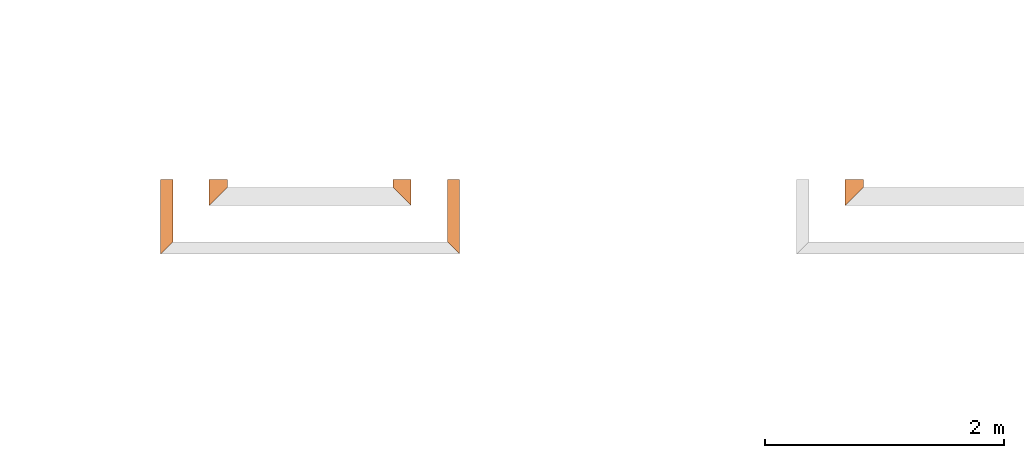
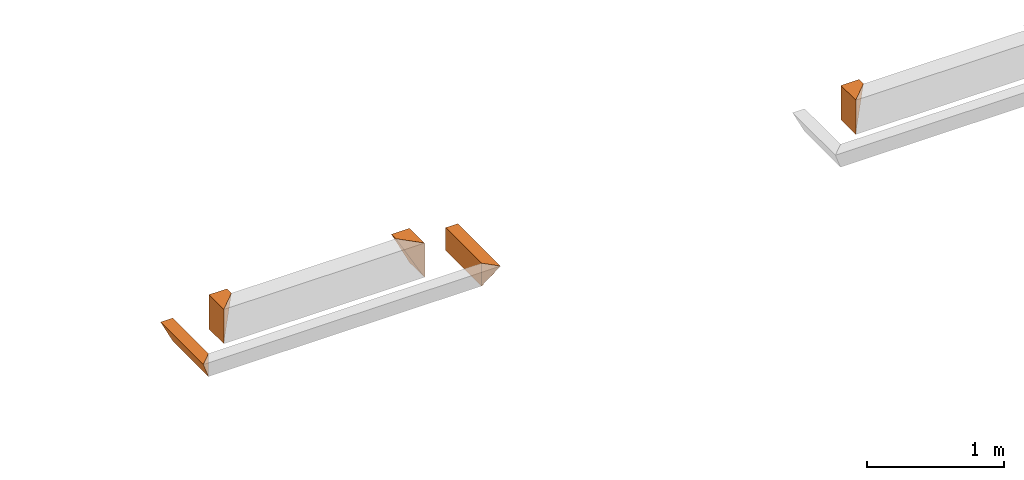
# One storey, part 5 of 8: 5 proxies.
"""IFC4 building model written with IfcOpenShell, lengths in feet."""

from ifc_helpers import new_model, entity, si_unit, converted_unit, derived_unit, direction, frame, origin, place, context, subcontext, project, spatial, type_object, element, save


model = new_model("IFC4")

# Units and contexts
model_context = context("Model", 3, precision=0.0001, world=origin(), true_north=direction((6.12303176911189e-17, 1.0)))
body_context = subcontext(model_context, "Body", "Model", "MODEL_VIEW")
ifc_project = project(units=[converted_unit("LENGTHUNIT", "FOOT", entity("IfcRatioMeasure", 0.3048), si_unit("LENGTHUNIT", "METRE"), dimensions=[1, 0, 0, 0, 0, 0, 0]), converted_unit("AREAUNIT", "SQUARE FOOT", entity("IfcRatioMeasure", 0.09290304), si_unit("AREAUNIT", "SQUARE_METRE"), dimensions=[2, 0, 0, 0, 0, 0, 0]), converted_unit("VOLUMEUNIT", "CUBIC FOOT", entity("IfcRatioMeasure", 0.028316846592), si_unit("VOLUMEUNIT", "CUBIC_METRE"), dimensions=[3, 0, 0, 0, 0, 0, 0]), converted_unit("PLANEANGLEUNIT", "DEGREE", entity("IfcRatioMeasure", 0.0174532925199433), si_unit("PLANEANGLEUNIT", "RADIAN"), dimensions=[0, 0, 0, 0, 0, 0, 0]), si_unit("MASSUNIT", "GRAM", prefix="KILO"), derived_unit("MASSDENSITYUNIT", [(si_unit("MASSUNIT", "GRAM", prefix="KILO"), 1), (si_unit("LENGTHUNIT", "METRE"), -3)]), derived_unit("MOMENTOFINERTIAUNIT", [(si_unit("LENGTHUNIT", "METRE"), 4)]), si_unit("TIMEUNIT", "SECOND"), si_unit("FREQUENCYUNIT", "HERTZ"), si_unit("THERMODYNAMICTEMPERATUREUNIT", "DEGREE_CELSIUS"), derived_unit("THERMALTRANSMITTANCEUNIT", [(si_unit("MASSUNIT", "GRAM", prefix="KILO"), 1), (si_unit("THERMODYNAMICTEMPERATUREUNIT", "KELVIN"), -1), (si_unit("TIMEUNIT", "SECOND"), -3)]), derived_unit("VOLUMETRICFLOWRATEUNIT", [(si_unit("LENGTHUNIT", "METRE"), 3), (si_unit("TIMEUNIT", "SECOND"), -1)]), si_unit("ELECTRICCURRENTUNIT", "AMPERE"), si_unit("ELECTRICVOLTAGEUNIT", "VOLT"), si_unit("POWERUNIT", "WATT"), si_unit("FORCEUNIT", "NEWTON"), si_unit("ILLUMINANCEUNIT", "LUX"), si_unit("LUMINOUSFLUXUNIT", "LUMEN"), si_unit("LUMINOUSINTENSITYUNIT", "CANDELA"), derived_unit("USERDEFINED", [(si_unit("MASSUNIT", "GRAM", prefix="KILO"), -1), (si_unit("LENGTHUNIT", "METRE"), -2), (si_unit("TIMEUNIT", "SECOND"), 3), (si_unit("LUMINOUSFLUXUNIT", "LUMEN"), 1)]), derived_unit("LINEARVELOCITYUNIT", [(si_unit("LENGTHUNIT", "METRE"), 1), (si_unit("TIMEUNIT", "SECOND"), -1)]), si_unit("PRESSUREUNIT", "PASCAL"), derived_unit("USERDEFINED", [(si_unit("LENGTHUNIT", "METRE"), -2), (si_unit("MASSUNIT", "GRAM", prefix="KILO"), 1), (si_unit("TIMEUNIT", "SECOND"), -2)]), derived_unit("LINEARFORCEUNIT", [(si_unit("MASSUNIT", "GRAM", prefix="KILO"), 1), (si_unit("LENGTHUNIT", "METRE"), 1), (si_unit("TIMEUNIT", "SECOND"), -2), (si_unit("LENGTHUNIT", "METRE"), -1)]), derived_unit("PLANARFORCEUNIT", [(si_unit("MASSUNIT", "GRAM", prefix="KILO"), 1), (si_unit("LENGTHUNIT", "METRE"), 1), (si_unit("TIMEUNIT", "SECOND"), -2), (si_unit("LENGTHUNIT", "METRE"), -2)])], contexts=[model_context])

# Site, building, storey
site_placement = place(None, origin())
site = spatial("IfcSite", under=ifc_project, at=site_placement, CompositionType="ELEMENT")
building_placement = place(site_placement, origin())
building = spatial("IfcBuilding", under=site, at=building_placement, CompositionType="ELEMENT")
storey_placement = place(building_placement, frame((0.0, 0.0, -12.6666666666667)))
storey = spatial("IfcBuildingStorey", under=building, at=storey_placement, Name="BASEMENT", CompositionType="ELEMENT", Elevation=-12.6666666666667)

# Proxies
building_element_proxy_type_1 = type_object("IfcBuildingElementProxyType", PredefinedType="NOTDEFINED")
proxy_1_placement = place(storey_placement, frame((-228.863157950076, 957.231726549317, 11.5833333333333)))
cartesian_point_1 = entity("IfcCartesianPoint", [0.5, 0.713552004822986, 0.0])
vertex_point_1 = entity("IfcVertexPoint", cartesian_point_1)
cartesian_point_2 = entity("IfcCartesianPoint", [0.0, 0.7135520048231, 1.0])
vertex_point_2 = entity("IfcVertexPoint", cartesian_point_2)
edge_curve_1 = entity("IfcEdgeCurve", vertex_point_1, vertex_point_2, entity("IfcTrimmedCurve", entity("IfcLine", cartesian_point_1, entity("IfcVector", entity("IfcDirection", [-0.44721359549996, 0.0, 0.894427190999915]), 1.0)), [cartesian_point_1], [cartesian_point_2], True, "CARTESIAN"), True)
cartesian_point_3 = entity("IfcCartesianPoint", [0.5, 0.713552004822986, 1.0])
vertex_point_3 = entity("IfcVertexPoint", cartesian_point_3)
ifc_direction_1 = entity("IfcDirection", [1.0, 0.0, 0.0])
edge_curve_2 = entity("IfcEdgeCurve", vertex_point_2, vertex_point_3, entity("IfcTrimmedCurve", entity("IfcLine", cartesian_point_2, entity("IfcVector", ifc_direction_1, 1.0)), [cartesian_point_2], [cartesian_point_3], True, "CARTESIAN"), True)
cartesian_point_4 = entity("IfcCartesianPoint", [0.5, 0.713552004822986, 0.669270833333341])
vertex_point_4 = entity("IfcVertexPoint", cartesian_point_4)
ifc_direction_2 = entity("IfcDirection", [0.0, 0.0, -1.0])
edge_curve_3 = entity("IfcEdgeCurve", vertex_point_3, vertex_point_4, entity("IfcTrimmedCurve", entity("IfcLine", cartesian_point_3, entity("IfcVector", ifc_direction_2, 1.0)), [cartesian_point_3], [cartesian_point_4], True, "CARTESIAN"), True)
edge_curve_4 = entity("IfcEdgeCurve", vertex_point_4, vertex_point_1, entity("IfcTrimmedCurve", entity("IfcLine", cartesian_point_4, entity("IfcVector", ifc_direction_2, 1.0)), [cartesian_point_4], [cartesian_point_1], True, "CARTESIAN"), True)
ifc_direction_3 = entity("IfcDirection", [0.0, 1.0, 0.0])
cartesian_point_5 = entity("IfcCartesianPoint", [0.0, 0.5, 1.0])
vertex_point_5 = entity("IfcVertexPoint", cartesian_point_5)
cartesian_point_6 = entity("IfcCartesianPoint", [0.499999999999972, 0.0, 0.0])
vertex_point_6 = entity("IfcVertexPoint", cartesian_point_6)
edge_curve_5 = entity("IfcEdgeCurve", vertex_point_5, vertex_point_6, entity("IfcTrimmedCurve", entity("IfcLine", cartesian_point_5, entity("IfcVector", entity("IfcDirection", [0.408248290463845, -0.408248290463868, -0.816496580927733]), 1.0)), [cartesian_point_5], [cartesian_point_6], True, "CARTESIAN"), True)
cartesian_point_7 = entity("IfcCartesianPoint", [0.499999999999972, 0.0, 0.669270833333341])
vertex_point_7 = entity("IfcVertexPoint", cartesian_point_7)
ifc_direction_4 = entity("IfcDirection", [0.0, 0.0, 1.0])
edge_curve_6 = entity("IfcEdgeCurve", vertex_point_6, vertex_point_7, entity("IfcTrimmedCurve", entity("IfcLine", cartesian_point_6, entity("IfcVector", ifc_direction_4, 1.0)), [cartesian_point_6], [cartesian_point_7], True, "CARTESIAN"), True)
cartesian_point_8 = entity("IfcCartesianPoint", [0.499999999999972, 0.0, 1.0])
vertex_point_8 = entity("IfcVertexPoint", cartesian_point_8)
edge_curve_7 = entity("IfcEdgeCurve", vertex_point_7, vertex_point_8, entity("IfcTrimmedCurve", entity("IfcLine", cartesian_point_7, entity("IfcVector", ifc_direction_4, 1.0)), [cartesian_point_7], [cartesian_point_8], True, "CARTESIAN"), True)
edge_curve_8 = entity("IfcEdgeCurve", vertex_point_8, vertex_point_5, entity("IfcTrimmedCurve", entity("IfcLine", cartesian_point_8, entity("IfcVector", entity("IfcDirection", [-0.707106781186527, 0.707106781186568, 0.0]), 1.0)), [cartesian_point_8], [cartesian_point_5], True, "CARTESIAN"), True)
ifc_direction_5 = entity("IfcDirection", [0.0, -1.0, 0.0])
edge_curve_9 = entity("IfcEdgeCurve", vertex_point_1, vertex_point_6, entity("IfcTrimmedCurve", entity("IfcLine", cartesian_point_1, entity("IfcVector", ifc_direction_5, 1.0)), [cartesian_point_1], [cartesian_point_6], True, "CARTESIAN"), True)
edge_curve_10 = entity("IfcEdgeCurve", vertex_point_5, vertex_point_2, entity("IfcTrimmedCurve", entity("IfcLine", cartesian_point_2, entity("IfcVector", ifc_direction_3, 1.0)), [cartesian_point_5], [cartesian_point_2], True, "CARTESIAN"), True)
edge_curve_11 = entity("IfcEdgeCurve", vertex_point_8, vertex_point_3, entity("IfcTrimmedCurve", entity("IfcLine", cartesian_point_3, entity("IfcVector", ifc_direction_3, 1.0)), [cartesian_point_8], [cartesian_point_3], True, "CARTESIAN"), True)
element("IfcBuildingElementProxy", 1, at=proxy_1_placement, inside=storey, type_object=building_element_proxy_type_1, PredefinedType="NOTDEFINED", context=body_context, shape_type="AdvancedBrep", body=[
    entity("IfcAdvancedBrep", entity("IfcClosedShell", [entity("IfcAdvancedFace", [entity("IfcFaceOuterBound", entity("IfcEdgeLoop", [entity("IfcOrientedEdge", None, None, edge_curve_1, True), entity("IfcOrientedEdge", None, None, edge_curve_2, True), entity("IfcOrientedEdge", None, None, edge_curve_3, True), entity("IfcOrientedEdge", None, None, edge_curve_4, True)]), True)], entity("IfcPlane", entity("IfcAxis2Placement3D", entity("IfcCartesianPoint", [-0.5, 0.7135520048231, 1.0]), ifc_direction_3, ifc_direction_2)), True), entity("IfcAdvancedFace", [entity("IfcFaceOuterBound", entity("IfcEdgeLoop", [entity("IfcOrientedEdge", None, None, edge_curve_5, True), entity("IfcOrientedEdge", None, None, edge_curve_6, True), entity("IfcOrientedEdge", None, None, edge_curve_7, True), entity("IfcOrientedEdge", None, None, edge_curve_8, True)]), True)], entity("IfcPlane", entity("IfcAxis2Placement3D", entity("IfcCartesianPoint", [0.499999999999972, 0.0, 2.0]), entity("IfcDirection", [-0.707106781186562, -0.707106781186533, 0.0]), entity("IfcDirection", [-0.707106781186533, 0.707106781186562, 0.0]))), True), entity("IfcAdvancedFace", [entity("IfcFaceOuterBound", entity("IfcEdgeLoop", [entity("IfcOrientedEdge", None, None, edge_curve_1, False), entity("IfcOrientedEdge", None, None, edge_curve_9, True), entity("IfcOrientedEdge", None, None, edge_curve_5, False), entity("IfcOrientedEdge", None, None, edge_curve_10, True)]), True)], entity("IfcPlane", entity("IfcAxis2Placement3D", cartesian_point_1, entity("IfcDirection", [-0.894427190999915, 0.0, -0.447213595499961]), ifc_direction_5)), True), entity("IfcAdvancedFace", [entity("IfcFaceOuterBound", entity("IfcEdgeLoop", [entity("IfcOrientedEdge", None, None, edge_curve_2, False), entity("IfcOrientedEdge", None, None, edge_curve_10, False), entity("IfcOrientedEdge", None, None, edge_curve_8, False), entity("IfcOrientedEdge", None, None, edge_curve_11, True)]), True)], entity("IfcPlane", entity("IfcAxis2Placement3D", cartesian_point_2, ifc_direction_4, ifc_direction_5)), True), entity("IfcAdvancedFace", [entity("IfcFaceOuterBound", entity("IfcEdgeLoop", [entity("IfcOrientedEdge", None, None, edge_curve_11, False), entity("IfcOrientedEdge", None, None, edge_curve_7, False), entity("IfcOrientedEdge", None, None, edge_curve_6, False), entity("IfcOrientedEdge", None, None, edge_curve_9, False), entity("IfcOrientedEdge", None, None, edge_curve_4, False), entity("IfcOrientedEdge", None, None, edge_curve_3, False)]), True)], entity("IfcPlane", entity("IfcAxis2Placement3D", cartesian_point_3, ifc_direction_1, ifc_direction_5)), True)])),
])
building_element_proxy_type_2 = type_object("IfcBuildingElementProxyType", PredefinedType="NOTDEFINED")
proxy_2_placement = place(storey_placement, frame((-227.363157950076, 955.89709113265, 11.5833333333333)))
cartesian_point_9 = entity("IfcCartesianPoint", [0.0, 2.04818742148973, 0.0])
vertex_point_9 = entity("IfcVertexPoint", cartesian_point_9)
cartesian_point_10 = entity("IfcCartesianPoint", [0.0, 2.04818742148973, 0.669270833333343])
vertex_point_10 = entity("IfcVertexPoint", cartesian_point_10)
ifc_direction_6 = entity("IfcDirection", [0.0, 0.0, 1.0])
edge_curve_12 = entity("IfcEdgeCurve", vertex_point_9, vertex_point_10, entity("IfcTrimmedCurve", entity("IfcLine", cartesian_point_9, entity("IfcVector", ifc_direction_6, 1.0)), [cartesian_point_9], [cartesian_point_10], True, "CARTESIAN"), True)
cartesian_point_11 = entity("IfcCartesianPoint", [0.334635416666885, 2.04818742148962, 0.669270833333343])
vertex_point_11 = entity("IfcVertexPoint", cartesian_point_11)
ifc_direction_7 = entity("IfcDirection", [1.0, 0.0, 0.0])
edge_curve_13 = entity("IfcEdgeCurve", vertex_point_10, vertex_point_11, entity("IfcTrimmedCurve", entity("IfcLine", cartesian_point_10, entity("IfcVector", ifc_direction_7, 1.0)), [cartesian_point_10], [cartesian_point_11], True, "CARTESIAN"), True)
edge_curve_14 = entity("IfcEdgeCurve", vertex_point_11, vertex_point_9, entity("IfcTrimmedCurve", entity("IfcLine", cartesian_point_11, entity("IfcVector", entity("IfcDirection", [-0.447213595499947, 0.0, -0.894427190999921]), 1.0)), [cartesian_point_11], [cartesian_point_9], True, "CARTESIAN"), True)
ifc_direction_8 = entity("IfcDirection", [0.0, 1.0, 0.0])
ifc_direction_9 = entity("IfcDirection", [0.0, 0.0, -1.0])
cartesian_point_12 = entity("IfcCartesianPoint", [0.0, 0.334635416666742, 0.0])
vertex_point_12 = entity("IfcVertexPoint", cartesian_point_12)
cartesian_point_13 = entity("IfcCartesianPoint", [0.334635416666828, 0.0, 0.669270833333343])
vertex_point_13 = entity("IfcVertexPoint", cartesian_point_13)
edge_curve_15 = entity("IfcEdgeCurve", vertex_point_12, vertex_point_13, entity("IfcTrimmedCurve", entity("IfcLine", cartesian_point_12, entity("IfcVector", entity("IfcDirection", [0.40824829046386, -0.408248290463825, 0.816496580927747]), 1.0)), [cartesian_point_12], [cartesian_point_13], True, "CARTESIAN"), True)
cartesian_point_14 = entity("IfcCartesianPoint", [0.0, 0.33463541666697, 0.669270833333343])
vertex_point_14 = entity("IfcVertexPoint", cartesian_point_14)
edge_curve_16 = entity("IfcEdgeCurve", vertex_point_13, vertex_point_14, entity("IfcTrimmedCurve", entity("IfcLine", cartesian_point_13, entity("IfcVector", entity("IfcDirection", [-0.707106781186517, 0.707106781186578, 0.0]), 1.0)), [cartesian_point_13], [cartesian_point_14], True, "CARTESIAN"), True)
edge_curve_17 = entity("IfcEdgeCurve", vertex_point_14, vertex_point_12, entity("IfcTrimmedCurve", entity("IfcLine", cartesian_point_14, entity("IfcVector", ifc_direction_9, 1.0)), [cartesian_point_14], [cartesian_point_12], True, "CARTESIAN"), True)
ifc_direction_10 = entity("IfcDirection", [0.0, -1.0, 0.0])
edge_curve_18 = entity("IfcEdgeCurve", vertex_point_9, vertex_point_12, entity("IfcTrimmedCurve", entity("IfcLine", cartesian_point_9, entity("IfcVector", ifc_direction_10, 1.0)), [cartesian_point_9], [cartesian_point_12], True, "CARTESIAN"), True)
edge_curve_19 = entity("IfcEdgeCurve", vertex_point_14, vertex_point_10, entity("IfcTrimmedCurve", entity("IfcLine", cartesian_point_14, entity("IfcVector", ifc_direction_8, 1.0)), [cartesian_point_14], [cartesian_point_10], True, "CARTESIAN"), True)
edge_curve_20 = entity("IfcEdgeCurve", vertex_point_11, vertex_point_13, entity("IfcTrimmedCurve", entity("IfcLine", cartesian_point_11, entity("IfcVector", ifc_direction_10, 1.0)), [cartesian_point_11], [cartesian_point_13], True, "CARTESIAN"), True)
element("IfcBuildingElementProxy", 2, at=proxy_2_placement, inside=storey, type_object=building_element_proxy_type_2, PredefinedType="NOTDEFINED", context=body_context, shape_type="AdvancedBrep", body=[
    entity("IfcAdvancedBrep", entity("IfcClosedShell", [entity("IfcAdvancedFace", [entity("IfcFaceOuterBound", entity("IfcEdgeLoop", [entity("IfcOrientedEdge", None, None, edge_curve_12, True), entity("IfcOrientedEdge", None, None, edge_curve_13, True), entity("IfcOrientedEdge", None, None, edge_curve_14, True)]), True)], entity("IfcPlane", entity("IfcAxis2Placement3D", entity("IfcCartesianPoint", [-1.0, 2.04818742148973, 1.0]), ifc_direction_8, ifc_direction_9)), True), entity("IfcAdvancedFace", [entity("IfcFaceOuterBound", entity("IfcEdgeLoop", [entity("IfcOrientedEdge", None, None, edge_curve_15, True), entity("IfcOrientedEdge", None, None, edge_curve_16, True), entity("IfcOrientedEdge", None, None, edge_curve_17, True)]), True)], entity("IfcPlane", entity("IfcAxis2Placement3D", entity("IfcCartesianPoint", [0.0, 0.334635416666742, 2.0]), entity("IfcDirection", [-0.707106781186562, -0.707106781186533, 0.0]), entity("IfcDirection", [-0.707106781186533, 0.707106781186562, 0.0]))), True), entity("IfcAdvancedFace", [entity("IfcFaceOuterBound", entity("IfcEdgeLoop", [entity("IfcOrientedEdge", None, None, edge_curve_18, True), entity("IfcOrientedEdge", None, None, edge_curve_17, False), entity("IfcOrientedEdge", None, None, edge_curve_19, True), entity("IfcOrientedEdge", None, None, edge_curve_12, False)]), True)], entity("IfcPlane", entity("IfcAxis2Placement3D", cartesian_point_9, entity("IfcDirection", [-1.0, 0.0, 0.0]), ifc_direction_10)), True), entity("IfcAdvancedFace", [entity("IfcFaceOuterBound", entity("IfcEdgeLoop", [entity("IfcOrientedEdge", None, None, edge_curve_18, False), entity("IfcOrientedEdge", None, None, edge_curve_14, False), entity("IfcOrientedEdge", None, None, edge_curve_20, True), entity("IfcOrientedEdge", None, None, edge_curve_15, False)]), True)], entity("IfcPlane", entity("IfcAxis2Placement3D", entity("IfcCartesianPoint", [0.500000000000227, 2.04818742148962, 1.0]), entity("IfcDirection", [0.894427190999915, 0.0, -0.447213595499961]), ifc_direction_10)), True), entity("IfcAdvancedFace", [entity("IfcFaceOuterBound", entity("IfcEdgeLoop", [entity("IfcOrientedEdge", None, None, edge_curve_13, False), entity("IfcOrientedEdge", None, None, edge_curve_19, False), entity("IfcOrientedEdge", None, None, edge_curve_16, False), entity("IfcOrientedEdge", None, None, edge_curve_20, False)]), True)], entity("IfcPlane", entity("IfcAxis2Placement3D", entity("IfcCartesianPoint", [85.6250051391024, 2.96484375000068, 0.669270833333343]), ifc_direction_6, ifc_direction_7)), True)])),
])
building_element_proxy_type_3 = type_object("IfcBuildingElementProxyType", PredefinedType="NOTDEFINED")
proxy_3_placement = place(storey_placement, frame((-233.904827319654, 957.231726549317, 11.5833333333333)))
cartesian_point_15 = entity("IfcCartesianPoint", [0.5, 0.7135520048231, 1.0])
vertex_point_15 = entity("IfcVertexPoint", cartesian_point_15)
cartesian_point_16 = entity("IfcCartesianPoint", [0.0, 0.713552004822986, 0.0])
vertex_point_16 = entity("IfcVertexPoint", cartesian_point_16)
edge_curve_21 = entity("IfcEdgeCurve", vertex_point_15, vertex_point_16, entity("IfcTrimmedCurve", entity("IfcLine", cartesian_point_15, entity("IfcVector", entity("IfcDirection", [-0.44721359549996, 0.0, -0.894427190999915]), 1.0)), [cartesian_point_15], [cartesian_point_16], True, "CARTESIAN"), True)
cartesian_point_17 = entity("IfcCartesianPoint", [0.0, 0.713552004822986, 0.669270833333341])
vertex_point_17 = entity("IfcVertexPoint", cartesian_point_17)
ifc_direction_11 = entity("IfcDirection", [0.0, 0.0, 1.0])
edge_curve_22 = entity("IfcEdgeCurve", vertex_point_16, vertex_point_17, entity("IfcTrimmedCurve", entity("IfcLine", cartesian_point_16, entity("IfcVector", ifc_direction_11, 1.0)), [cartesian_point_16], [cartesian_point_17], True, "CARTESIAN"), True)
cartesian_point_18 = entity("IfcCartesianPoint", [0.0, 0.713552004822986, 1.0])
vertex_point_18 = entity("IfcVertexPoint", cartesian_point_18)
edge_curve_23 = entity("IfcEdgeCurve", vertex_point_17, vertex_point_18, entity("IfcTrimmedCurve", entity("IfcLine", cartesian_point_17, entity("IfcVector", ifc_direction_11, 1.0)), [cartesian_point_17], [cartesian_point_18], True, "CARTESIAN"), True)
edge_curve_24 = entity("IfcEdgeCurve", vertex_point_18, vertex_point_15, entity("IfcTrimmedCurve", entity("IfcLine", cartesian_point_18, entity("IfcVector", entity("IfcDirection", [1.0, 0.0, 0.0]), 1.0)), [cartesian_point_18], [cartesian_point_15], True, "CARTESIAN"), True)
ifc_direction_12 = entity("IfcDirection", [0.0, 1.0, 0.0])
ifc_direction_13 = entity("IfcDirection", [0.0, 0.0, -1.0])
cartesian_point_19 = entity("IfcCartesianPoint", [0.0, 0.0, 0.0])
vertex_point_19 = entity("IfcVertexPoint", cartesian_point_19)
cartesian_point_20 = entity("IfcCartesianPoint", [0.500000000000028, 0.5, 1.0])
vertex_point_20 = entity("IfcVertexPoint", cartesian_point_20)
edge_curve_25 = entity("IfcEdgeCurve", vertex_point_19, vertex_point_20, entity("IfcTrimmedCurve", entity("IfcLine", cartesian_point_19, entity("IfcVector", entity("IfcDirection", [0.408248290463864, 0.408248290463864, 0.816496580927725]), 1.0)), [cartesian_point_19], [cartesian_point_20], True, "CARTESIAN"), True)
cartesian_point_21 = entity("IfcCartesianPoint", [0.0, 0.0, 1.0])
vertex_point_21 = entity("IfcVertexPoint", cartesian_point_21)
edge_curve_26 = entity("IfcEdgeCurve", vertex_point_20, vertex_point_21, entity("IfcTrimmedCurve", entity("IfcLine", cartesian_point_20, entity("IfcVector", entity("IfcDirection", [-0.707106781186547, -0.707106781186547, 0.0]), 1.0)), [cartesian_point_20], [cartesian_point_21], True, "CARTESIAN"), True)
cartesian_point_22 = entity("IfcCartesianPoint", [0.0, 0.0, 0.669270833333341])
vertex_point_22 = entity("IfcVertexPoint", cartesian_point_22)
edge_curve_27 = entity("IfcEdgeCurve", vertex_point_21, vertex_point_22, entity("IfcTrimmedCurve", entity("IfcLine", cartesian_point_21, entity("IfcVector", ifc_direction_13, 1.0)), [cartesian_point_21], [cartesian_point_22], True, "CARTESIAN"), True)
edge_curve_28 = entity("IfcEdgeCurve", vertex_point_22, vertex_point_19, entity("IfcTrimmedCurve", entity("IfcLine", cartesian_point_22, entity("IfcVector", ifc_direction_13, 1.0)), [cartesian_point_22], [cartesian_point_19], True, "CARTESIAN"), True)
ifc_direction_14 = entity("IfcDirection", [0.0, -1.0, 0.0])
edge_curve_29 = entity("IfcEdgeCurve", vertex_point_15, vertex_point_20, entity("IfcTrimmedCurve", entity("IfcLine", cartesian_point_15, entity("IfcVector", ifc_direction_14, 1.0)), [cartesian_point_15], [cartesian_point_20], True, "CARTESIAN"), True)
edge_curve_30 = entity("IfcEdgeCurve", vertex_point_19, vertex_point_16, entity("IfcTrimmedCurve", entity("IfcLine", cartesian_point_16, entity("IfcVector", ifc_direction_12, 1.0)), [cartesian_point_19], [cartesian_point_16], True, "CARTESIAN"), True)
edge_curve_31 = entity("IfcEdgeCurve", vertex_point_18, vertex_point_21, entity("IfcTrimmedCurve", entity("IfcLine", cartesian_point_18, entity("IfcVector", ifc_direction_14, 1.0)), [cartesian_point_18], [cartesian_point_21], True, "CARTESIAN"), True)
element("IfcBuildingElementProxy", 3, at=proxy_3_placement, inside=storey, type_object=building_element_proxy_type_3, PredefinedType="NOTDEFINED", context=body_context, shape_type="AdvancedBrep", body=[
    entity("IfcAdvancedBrep", entity("IfcClosedShell", [entity("IfcAdvancedFace", [entity("IfcFaceOuterBound", entity("IfcEdgeLoop", [entity("IfcOrientedEdge", None, None, edge_curve_21, True), entity("IfcOrientedEdge", None, None, edge_curve_22, True), entity("IfcOrientedEdge", None, None, edge_curve_23, True), entity("IfcOrientedEdge", None, None, edge_curve_24, True)]), True)], entity("IfcPlane", entity("IfcAxis2Placement3D", entity("IfcCartesianPoint", [-1.0, 0.713552004822986, 1.0]), ifc_direction_12, ifc_direction_13)), True), entity("IfcAdvancedFace", [entity("IfcFaceOuterBound", entity("IfcEdgeLoop", [entity("IfcOrientedEdge", None, None, edge_curve_25, True), entity("IfcOrientedEdge", None, None, edge_curve_26, True), entity("IfcOrientedEdge", None, None, edge_curve_27, True), entity("IfcOrientedEdge", None, None, edge_curve_28, True)]), True)], entity("IfcPlane", entity("IfcAxis2Placement3D", cartesian_point_19, entity("IfcDirection", [0.707106781186548, -0.707106781186548, 0.0]), entity("IfcDirection", [0.707106781186548, 0.707106781186548, 0.0]))), True), entity("IfcAdvancedFace", [entity("IfcFaceOuterBound", entity("IfcEdgeLoop", [entity("IfcOrientedEdge", None, None, edge_curve_21, False), entity("IfcOrientedEdge", None, None, edge_curve_29, True), entity("IfcOrientedEdge", None, None, edge_curve_25, False), entity("IfcOrientedEdge", None, None, edge_curve_30, True)]), True)], entity("IfcPlane", entity("IfcAxis2Placement3D", cartesian_point_15, entity("IfcDirection", [0.894427190999915, 0.0, -0.447213595499961]), ifc_direction_14)), True), entity("IfcAdvancedFace", [entity("IfcFaceOuterBound", entity("IfcEdgeLoop", [entity("IfcOrientedEdge", None, None, edge_curve_24, False), entity("IfcOrientedEdge", None, None, edge_curve_31, True), entity("IfcOrientedEdge", None, None, edge_curve_26, False), entity("IfcOrientedEdge", None, None, edge_curve_29, False)]), True)], entity("IfcPlane", entity("IfcAxis2Placement3D", cartesian_point_18, ifc_direction_11, ifc_direction_14)), True), entity("IfcAdvancedFace", [entity("IfcFaceOuterBound", entity("IfcEdgeLoop", [entity("IfcOrientedEdge", None, None, edge_curve_31, False), entity("IfcOrientedEdge", None, None, edge_curve_23, False), entity("IfcOrientedEdge", None, None, edge_curve_22, False), entity("IfcOrientedEdge", None, None, edge_curve_30, False), entity("IfcOrientedEdge", None, None, edge_curve_28, False), entity("IfcOrientedEdge", None, None, edge_curve_27, False)]), True)], entity("IfcPlane", entity("IfcAxis2Placement3D", cartesian_point_16, entity("IfcDirection", [-1.0, 0.0, 0.0]), ifc_direction_14)), True)])),
])
building_element_proxy_type_4 = type_object("IfcBuildingElementProxyType", PredefinedType="NOTDEFINED")
proxy_4_placement = place(storey_placement, frame((-235.239462736321, 955.89709113265, 11.5833333333333)))
cartesian_point_23 = entity("IfcCartesianPoint", [0.334635416666686, 2.04818742148973, 0.0])
vertex_point_23 = entity("IfcVertexPoint", cartesian_point_23)
cartesian_point_24 = entity("IfcCartesianPoint", [0.0, 2.04818742148973, 0.669270833333343])
vertex_point_24 = entity("IfcVertexPoint", cartesian_point_24)
edge_curve_32 = entity("IfcEdgeCurve", vertex_point_23, vertex_point_24, entity("IfcTrimmedCurve", entity("IfcLine", cartesian_point_23, entity("IfcVector", entity("IfcDirection", [-0.447213595499947, 0.0, 0.894427190999921]), 1.0)), [cartesian_point_23], [cartesian_point_24], True, "CARTESIAN"), True)
cartesian_point_25 = entity("IfcCartesianPoint", [0.334635416666686, 2.04818742148973, 0.669270833333343])
vertex_point_25 = entity("IfcVertexPoint", cartesian_point_25)
ifc_direction_15 = entity("IfcDirection", [1.0, 0.0, 0.0])
edge_curve_33 = entity("IfcEdgeCurve", vertex_point_24, vertex_point_25, entity("IfcTrimmedCurve", entity("IfcLine", cartesian_point_24, entity("IfcVector", ifc_direction_15, 1.0)), [cartesian_point_24], [cartesian_point_25], True, "CARTESIAN"), True)
ifc_direction_16 = entity("IfcDirection", [0.0, 0.0, -1.0])
edge_curve_34 = entity("IfcEdgeCurve", vertex_point_25, vertex_point_23, entity("IfcTrimmedCurve", entity("IfcLine", cartesian_point_25, entity("IfcVector", ifc_direction_16, 1.0)), [cartesian_point_25], [cartesian_point_23], True, "CARTESIAN"), True)
ifc_direction_17 = entity("IfcDirection", [0.0, 1.0, 0.0])
cartesian_point_26 = entity("IfcCartesianPoint", [0.334635416666742, 0.334635416666742, 0.0])
vertex_point_26 = entity("IfcVertexPoint", cartesian_point_26)
cartesian_point_27 = entity("IfcCartesianPoint", [0.334635416666742, 0.334635416666742, 0.669270833333343])
vertex_point_27 = entity("IfcVertexPoint", cartesian_point_27)
ifc_direction_18 = entity("IfcDirection", [0.0, 0.0, 1.0])
edge_curve_35 = entity("IfcEdgeCurve", vertex_point_26, vertex_point_27, entity("IfcTrimmedCurve", entity("IfcLine", cartesian_point_26, entity("IfcVector", ifc_direction_18, 1.0)), [cartesian_point_26], [cartesian_point_27], True, "CARTESIAN"), True)
cartesian_point_28 = entity("IfcCartesianPoint", [0.0, 0.0, 0.669270833333343])
vertex_point_28 = entity("IfcVertexPoint", cartesian_point_28)
edge_curve_36 = entity("IfcEdgeCurve", vertex_point_27, vertex_point_28, entity("IfcTrimmedCurve", entity("IfcLine", cartesian_point_27, entity("IfcVector", entity("IfcDirection", [-0.707106781186578, -0.707106781186517, 0.0]), 1.0)), [cartesian_point_27], [cartesian_point_28], True, "CARTESIAN"), True)
edge_curve_37 = entity("IfcEdgeCurve", vertex_point_28, vertex_point_26, entity("IfcTrimmedCurve", entity("IfcLine", cartesian_point_28, entity("IfcVector", entity("IfcDirection", [0.40824829046386, 0.408248290463825, -0.816496580927747]), 1.0)), [cartesian_point_28], [cartesian_point_26], True, "CARTESIAN"), True)
edge_curve_38 = entity("IfcEdgeCurve", vertex_point_26, vertex_point_23, entity("IfcTrimmedCurve", entity("IfcLine", cartesian_point_23, entity("IfcVector", ifc_direction_17, 1.0)), [cartesian_point_26], [cartesian_point_23], True, "CARTESIAN"), True)
ifc_direction_19 = entity("IfcDirection", [0.0, -1.0, 0.0])
edge_curve_39 = entity("IfcEdgeCurve", vertex_point_25, vertex_point_27, entity("IfcTrimmedCurve", entity("IfcLine", cartesian_point_25, entity("IfcVector", ifc_direction_19, 1.0)), [cartesian_point_25], [cartesian_point_27], True, "CARTESIAN"), True)
edge_curve_40 = entity("IfcEdgeCurve", vertex_point_28, vertex_point_24, entity("IfcTrimmedCurve", entity("IfcLine", cartesian_point_28, entity("IfcVector", ifc_direction_17, 1.0)), [cartesian_point_28], [cartesian_point_24], True, "CARTESIAN"), True)
element("IfcBuildingElementProxy", 4, at=proxy_4_placement, inside=storey, type_object=building_element_proxy_type_4, PredefinedType="NOTDEFINED", context=body_context, shape_type="AdvancedBrep", body=[
    entity("IfcAdvancedBrep", entity("IfcClosedShell", [entity("IfcAdvancedFace", [entity("IfcFaceOuterBound", entity("IfcEdgeLoop", [entity("IfcOrientedEdge", None, None, edge_curve_32, True), entity("IfcOrientedEdge", None, None, edge_curve_33, True), entity("IfcOrientedEdge", None, None, edge_curve_34, True)]), True)], entity("IfcPlane", entity("IfcAxis2Placement3D", entity("IfcCartesianPoint", [-0.665364583333314, 2.04818742148973, 1.0]), ifc_direction_17, ifc_direction_16)), True), entity("IfcAdvancedFace", [entity("IfcFaceOuterBound", entity("IfcEdgeLoop", [entity("IfcOrientedEdge", None, None, edge_curve_35, True), entity("IfcOrientedEdge", None, None, edge_curve_36, True), entity("IfcOrientedEdge", None, None, edge_curve_37, True)]), True)], entity("IfcPlane", entity("IfcAxis2Placement3D", cartesian_point_26, entity("IfcDirection", [0.707106781186548, -0.707106781186548, 0.0]), entity("IfcDirection", [0.707106781186548, 0.707106781186548, 0.0]))), True), entity("IfcAdvancedFace", [entity("IfcFaceOuterBound", entity("IfcEdgeLoop", [entity("IfcOrientedEdge", None, None, edge_curve_38, True), entity("IfcOrientedEdge", None, None, edge_curve_34, False), entity("IfcOrientedEdge", None, None, edge_curve_39, True), entity("IfcOrientedEdge", None, None, edge_curve_35, False)]), True)], entity("IfcPlane", entity("IfcAxis2Placement3D", entity("IfcCartesianPoint", [0.334635416666686, 2.04818742148973, 1.0]), ifc_direction_15, ifc_direction_19)), True), entity("IfcAdvancedFace", [entity("IfcFaceOuterBound", entity("IfcEdgeLoop", [entity("IfcOrientedEdge", None, None, edge_curve_38, False), entity("IfcOrientedEdge", None, None, edge_curve_37, False), entity("IfcOrientedEdge", None, None, edge_curve_40, True), entity("IfcOrientedEdge", None, None, edge_curve_32, False)]), True)], entity("IfcPlane", entity("IfcAxis2Placement3D", cartesian_point_23, entity("IfcDirection", [-0.894427190999915, 0.0, -0.447213595499961]), ifc_direction_19)), True), entity("IfcAdvancedFace", [entity("IfcFaceOuterBound", entity("IfcEdgeLoop", [entity("IfcOrientedEdge", None, None, edge_curve_33, False), entity("IfcOrientedEdge", None, None, edge_curve_40, False), entity("IfcOrientedEdge", None, None, edge_curve_36, False), entity("IfcOrientedEdge", None, None, edge_curve_39, False)]), True)], entity("IfcPlane", entity("IfcAxis2Placement3D", entity("IfcCartesianPoint", [93.5013099253468, 2.96484375000045, 0.669270833333343]), ifc_direction_18, ifc_direction_15)), True)])),
])
building_element_proxy_type_5 = type_object("IfcBuildingElementProxyType", PredefinedType="NOTDEFINED")
proxy_5_placement = place(storey_placement, frame((-216.446494139458, 957.231726549316, 11.5833333333333)))
cartesian_point_29 = entity("IfcCartesianPoint", [0.5, 0.713552004823214, 1.0])
vertex_point_29 = entity("IfcVertexPoint", cartesian_point_29)
cartesian_point_30 = entity("IfcCartesianPoint", [0.0, 0.7135520048231, 0.0])
vertex_point_30 = entity("IfcVertexPoint", cartesian_point_30)
edge_curve_41 = entity("IfcEdgeCurve", vertex_point_29, vertex_point_30, entity("IfcTrimmedCurve", entity("IfcLine", cartesian_point_29, entity("IfcVector", entity("IfcDirection", [-0.44721359549996, 0.0, -0.894427190999915]), 1.0)), [cartesian_point_29], [cartesian_point_30], True, "CARTESIAN"), True)
cartesian_point_31 = entity("IfcCartesianPoint", [0.0, 0.7135520048231, 0.669270833333341])
vertex_point_31 = entity("IfcVertexPoint", cartesian_point_31)
ifc_direction_20 = entity("IfcDirection", [0.0, 0.0, 1.0])
edge_curve_42 = entity("IfcEdgeCurve", vertex_point_30, vertex_point_31, entity("IfcTrimmedCurve", entity("IfcLine", cartesian_point_30, entity("IfcVector", ifc_direction_20, 1.0)), [cartesian_point_30], [cartesian_point_31], True, "CARTESIAN"), True)
cartesian_point_32 = entity("IfcCartesianPoint", [0.0, 0.7135520048231, 1.0])
vertex_point_32 = entity("IfcVertexPoint", cartesian_point_32)
edge_curve_43 = entity("IfcEdgeCurve", vertex_point_31, vertex_point_32, entity("IfcTrimmedCurve", entity("IfcLine", cartesian_point_31, entity("IfcVector", ifc_direction_20, 1.0)), [cartesian_point_31], [cartesian_point_32], True, "CARTESIAN"), True)
edge_curve_44 = entity("IfcEdgeCurve", vertex_point_32, vertex_point_29, entity("IfcTrimmedCurve", entity("IfcLine", cartesian_point_32, entity("IfcVector", entity("IfcDirection", [1.0, 0.0, 0.0]), 1.0)), [cartesian_point_32], [cartesian_point_29], True, "CARTESIAN"), True)
ifc_direction_21 = entity("IfcDirection", [0.0, 1.0, 0.0])
ifc_direction_22 = entity("IfcDirection", [0.0, 0.0, -1.0])
cartesian_point_33 = entity("IfcCartesianPoint", [0.0, 0.0, 0.0])
vertex_point_33 = entity("IfcVertexPoint", cartesian_point_33)
cartesian_point_34 = entity("IfcCartesianPoint", [0.500000000000028, 0.5, 1.0])
vertex_point_34 = entity("IfcVertexPoint", cartesian_point_34)
edge_curve_45 = entity("IfcEdgeCurve", vertex_point_33, vertex_point_34, entity("IfcTrimmedCurve", entity("IfcLine", cartesian_point_33, entity("IfcVector", entity("IfcDirection", [0.408248290463864, 0.408248290463864, 0.816496580927725]), 1.0)), [cartesian_point_33], [cartesian_point_34], True, "CARTESIAN"), True)
cartesian_point_35 = entity("IfcCartesianPoint", [0.0, 0.0, 1.0])
vertex_point_35 = entity("IfcVertexPoint", cartesian_point_35)
edge_curve_46 = entity("IfcEdgeCurve", vertex_point_34, vertex_point_35, entity("IfcTrimmedCurve", entity("IfcLine", cartesian_point_34, entity("IfcVector", entity("IfcDirection", [-0.707106781186547, -0.707106781186547, 0.0]), 1.0)), [cartesian_point_34], [cartesian_point_35], True, "CARTESIAN"), True)
cartesian_point_36 = entity("IfcCartesianPoint", [0.0, 0.0, 0.669270833333341])
vertex_point_36 = entity("IfcVertexPoint", cartesian_point_36)
edge_curve_47 = entity("IfcEdgeCurve", vertex_point_35, vertex_point_36, entity("IfcTrimmedCurve", entity("IfcLine", cartesian_point_35, entity("IfcVector", ifc_direction_22, 1.0)), [cartesian_point_35], [cartesian_point_36], True, "CARTESIAN"), True)
edge_curve_48 = entity("IfcEdgeCurve", vertex_point_36, vertex_point_33, entity("IfcTrimmedCurve", entity("IfcLine", cartesian_point_36, entity("IfcVector", ifc_direction_22, 1.0)), [cartesian_point_36], [cartesian_point_33], True, "CARTESIAN"), True)
ifc_direction_23 = entity("IfcDirection", [0.0, -1.0, 0.0])
edge_curve_49 = entity("IfcEdgeCurve", vertex_point_29, vertex_point_34, entity("IfcTrimmedCurve", entity("IfcLine", cartesian_point_29, entity("IfcVector", ifc_direction_23, 1.0)), [cartesian_point_29], [cartesian_point_34], True, "CARTESIAN"), True)
edge_curve_50 = entity("IfcEdgeCurve", vertex_point_33, vertex_point_30, entity("IfcTrimmedCurve", entity("IfcLine", cartesian_point_30, entity("IfcVector", ifc_direction_21, 1.0)), [cartesian_point_33], [cartesian_point_30], True, "CARTESIAN"), True)
edge_curve_51 = entity("IfcEdgeCurve", vertex_point_32, vertex_point_35, entity("IfcTrimmedCurve", entity("IfcLine", cartesian_point_32, entity("IfcVector", ifc_direction_23, 1.0)), [cartesian_point_32], [cartesian_point_35], True, "CARTESIAN"), True)
element("IfcBuildingElementProxy", 5, at=proxy_5_placement, inside=storey, type_object=building_element_proxy_type_5, PredefinedType="NOTDEFINED", context=body_context, shape_type="AdvancedBrep", body=[
    entity("IfcAdvancedBrep", entity("IfcClosedShell", [entity("IfcAdvancedFace", [entity("IfcFaceOuterBound", entity("IfcEdgeLoop", [entity("IfcOrientedEdge", None, None, edge_curve_41, True), entity("IfcOrientedEdge", None, None, edge_curve_42, True), entity("IfcOrientedEdge", None, None, edge_curve_43, True), entity("IfcOrientedEdge", None, None, edge_curve_44, True)]), True)], entity("IfcPlane", entity("IfcAxis2Placement3D", entity("IfcCartesianPoint", [-1.0, 0.7135520048231, 1.0]), ifc_direction_21, ifc_direction_22)), True), entity("IfcAdvancedFace", [entity("IfcFaceOuterBound", entity("IfcEdgeLoop", [entity("IfcOrientedEdge", None, None, edge_curve_45, True), entity("IfcOrientedEdge", None, None, edge_curve_46, True), entity("IfcOrientedEdge", None, None, edge_curve_47, True), entity("IfcOrientedEdge", None, None, edge_curve_48, True)]), True)], entity("IfcPlane", entity("IfcAxis2Placement3D", cartesian_point_33, entity("IfcDirection", [0.707106781186548, -0.707106781186548, 0.0]), entity("IfcDirection", [0.707106781186548, 0.707106781186548, 0.0]))), True), entity("IfcAdvancedFace", [entity("IfcFaceOuterBound", entity("IfcEdgeLoop", [entity("IfcOrientedEdge", None, None, edge_curve_41, False), entity("IfcOrientedEdge", None, None, edge_curve_49, True), entity("IfcOrientedEdge", None, None, edge_curve_45, False), entity("IfcOrientedEdge", None, None, edge_curve_50, True)]), True)], entity("IfcPlane", entity("IfcAxis2Placement3D", cartesian_point_29, entity("IfcDirection", [0.894427190999915, 0.0, -0.447213595499961]), ifc_direction_23)), True), entity("IfcAdvancedFace", [entity("IfcFaceOuterBound", entity("IfcEdgeLoop", [entity("IfcOrientedEdge", None, None, edge_curve_44, False), entity("IfcOrientedEdge", None, None, edge_curve_51, True), entity("IfcOrientedEdge", None, None, edge_curve_46, False), entity("IfcOrientedEdge", None, None, edge_curve_49, False)]), True)], entity("IfcPlane", entity("IfcAxis2Placement3D", cartesian_point_32, ifc_direction_20, ifc_direction_23)), True), entity("IfcAdvancedFace", [entity("IfcFaceOuterBound", entity("IfcEdgeLoop", [entity("IfcOrientedEdge", None, None, edge_curve_51, False), entity("IfcOrientedEdge", None, None, edge_curve_43, False), entity("IfcOrientedEdge", None, None, edge_curve_42, False), entity("IfcOrientedEdge", None, None, edge_curve_50, False), entity("IfcOrientedEdge", None, None, edge_curve_48, False), entity("IfcOrientedEdge", None, None, edge_curve_47, False)]), True)], entity("IfcPlane", entity("IfcAxis2Placement3D", cartesian_point_30, entity("IfcDirection", [-1.0, 0.0, 0.0]), ifc_direction_23)), True)])),
])

save(model, "model.ifc")
